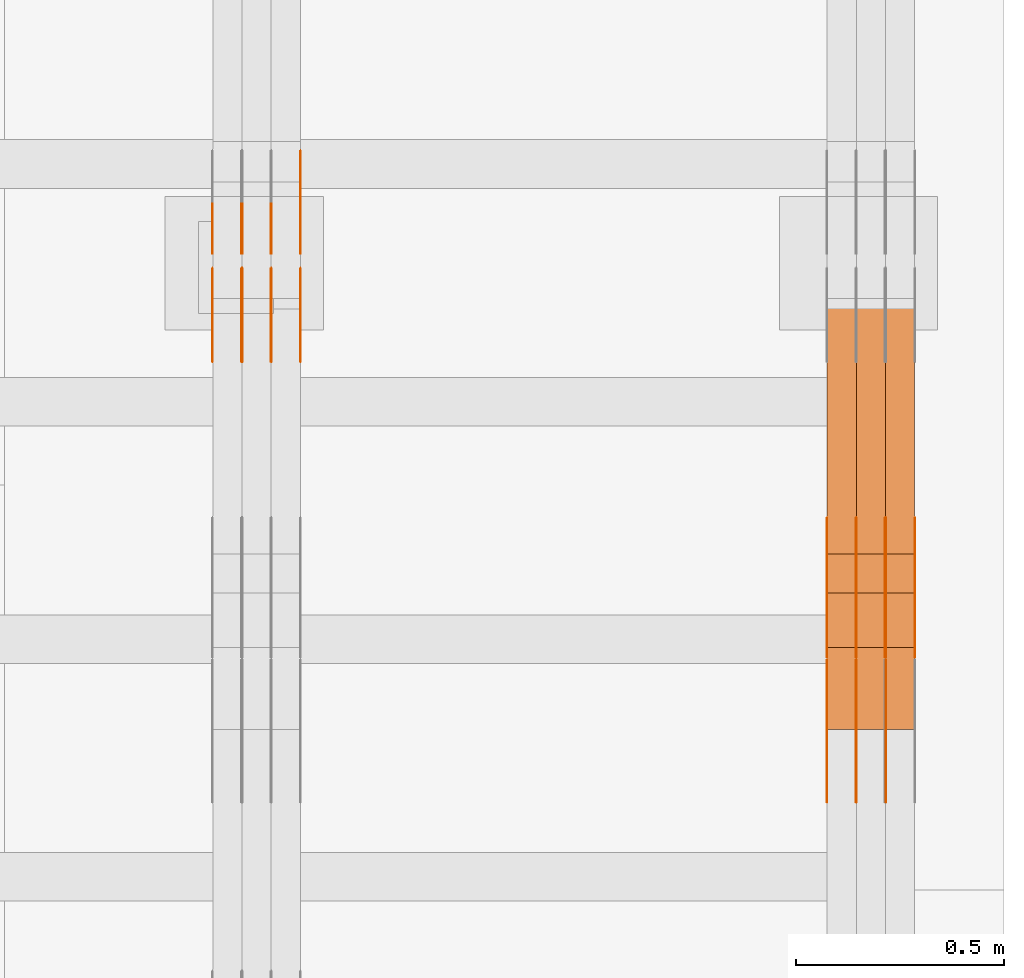
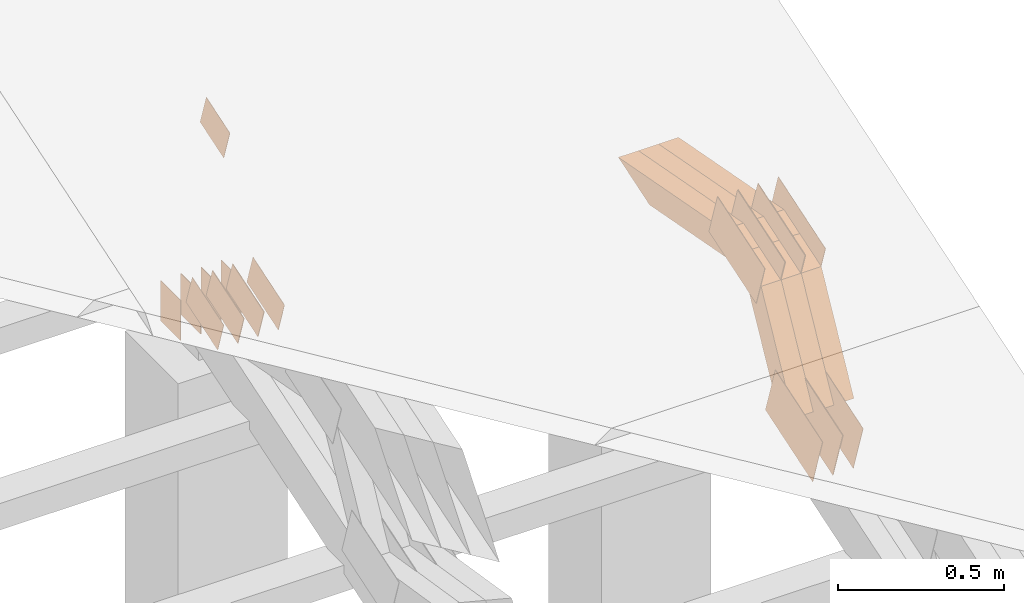
# One storey, part 320 of 385: 29 proxies.
"""IFC2X3 building model written with IfcOpenShell, lengths in millimetres."""

from ifc_helpers import new_model, entity, si_unit, converted_unit, derived_unit, direction, frame, frame_2d, origin, place, context, subcontext, project, spatial, polyline, rectangle, outline, extrude, source, transform, mapped, material, type_object, type_shapes, element, save


model = new_model("IFC2X3")

# Units and contexts
model_context = context("Model", 3, precision=0.01, world=origin(), true_north=direction((6.12303176911189e-17, 1.0)))
body_context = subcontext(model_context, "Body", "Model", "MODEL_VIEW")
ifc_project = project(units=[si_unit("LENGTHUNIT", "METRE", prefix="MILLI"), si_unit("AREAUNIT", "SQUARE_METRE"), si_unit("VOLUMEUNIT", "CUBIC_METRE"), converted_unit("PLANEANGLEUNIT", "DEGREE", entity("IfcRatioMeasure", 0.0174532925199433), si_unit("PLANEANGLEUNIT", "RADIAN"), dimensions=[0, 0, 0, 0, 0, 0, 0]), si_unit("MASSUNIT", "GRAM", prefix="KILO"), derived_unit("MASSDENSITYUNIT", [(si_unit("MASSUNIT", "GRAM", prefix="KILO"), 1), (si_unit("LENGTHUNIT", "METRE"), -3)]), si_unit("TIMEUNIT", "SECOND"), si_unit("FREQUENCYUNIT", "HERTZ"), si_unit("THERMODYNAMICTEMPERATUREUNIT", "DEGREE_CELSIUS"), derived_unit("THERMALTRANSMITTANCEUNIT", [(si_unit("MASSUNIT", "GRAM", prefix="KILO"), 1), (si_unit("THERMODYNAMICTEMPERATUREUNIT", "KELVIN"), -1), (si_unit("TIMEUNIT", "SECOND"), -3)]), derived_unit("VOLUMETRICFLOWRATEUNIT", [(si_unit("LENGTHUNIT", "METRE"), 3), (si_unit("TIMEUNIT", "SECOND"), -1)]), si_unit("ELECTRICCURRENTUNIT", "AMPERE"), si_unit("ELECTRICVOLTAGEUNIT", "VOLT"), si_unit("POWERUNIT", "WATT"), si_unit("FORCEUNIT", "NEWTON", prefix="KILO"), si_unit("ILLUMINANCEUNIT", "LUX"), si_unit("LUMINOUSFLUXUNIT", "LUMEN"), si_unit("LUMINOUSINTENSITYUNIT", "CANDELA"), derived_unit("USERDEFINED", [(si_unit("MASSUNIT", "GRAM", prefix="KILO"), -1), (si_unit("LENGTHUNIT", "METRE"), -2), (si_unit("TIMEUNIT", "SECOND"), 3), (si_unit("LUMINOUSFLUXUNIT", "LUMEN"), 1)]), derived_unit("LINEARVELOCITYUNIT", [(si_unit("LENGTHUNIT", "METRE"), 1), (si_unit("TIMEUNIT", "SECOND"), -1)]), si_unit("PRESSUREUNIT", "PASCAL"), derived_unit("USERDEFINED", [(si_unit("LENGTHUNIT", "METRE"), -2), (si_unit("MASSUNIT", "GRAM", prefix="KILO"), 1), (si_unit("TIMEUNIT", "SECOND"), -2)])], contexts=[model_context])

# Site, building, storey
site_placement = place(None, origin())
site = spatial("IfcSite", under=ifc_project, at=site_placement, CompositionType="ELEMENT")
building_placement = place(site_placement, origin())
building = spatial("IfcBuilding", under=site, at=building_placement, CompositionType="ELEMENT")
storey_placement = place(building_placement, origin())
storey = spatial("IfcBuildingStorey", under=building, at=storey_placement, Name="Default", CompositionType="ELEMENT", Elevation=0.0)

# Proxies
ifc_material_1 = material(Name="IfcSurfaceStyle #621526")
building_element_proxy_type_1 = type_object("IfcBuildingElementProxyType", PredefinedType="NOTDEFINED", material=ifc_material_1)
shared_shape_1 = source(origin(), body_context, "Body", "SweptSolid", [
    extrude(outline(polyline([(-149.99966632326, -95.9999759039407), (149.999881095801, -95.9999759039407), (150.000557367591, 95.9999759039407), (-150.000772140132, 95.9999759039406), (-149.99966632326, -95.9999759039407)])), frame((150.000557367591, 96.0004291135906, 0.0), z_axis=(0.0, 0.0, 1.0), x_axis=(-1.0, 0.0, 0.0)), (0.0, 0.0, 1.0), 1.29999999999999),
])
type_shapes(building_element_proxy_type_1, [shared_shape_1])
proxy_1_placement = place(building_placement, frame((49791.3, 10934.7734375, 2766.8759765625), z_axis=(-1.0, 0.0, 0.0), x_axis=(0.0, 0.951056516295124, 0.309016994375039)))
element("IfcBuildingElementProxy", 1, at=proxy_1_placement, inside=storey, type_object=building_element_proxy_type_1, material=ifc_material_1, context=body_context, shape_type="MappedRepresentation", body=[
    mapped(shared_shape_1, transform((0.0, 0.0, 0.0), scale=1.0)),
])
ifc_material_2 = material(Name="IfcSurfaceStyle #621469")
building_element_proxy_type_2 = type_object("IfcBuildingElementProxyType", PredefinedType="NOTDEFINED", material=ifc_material_2)
shared_shape_2 = source(origin(), body_context, "Body", "SweptSolid", [
    extrude(outline(polyline([(-149.99966632326, -95.9999759039407), (149.999881095801, -95.9999759039407), (150.000557367591, 95.9999759039407), (-150.000772140132, 95.9999759039406), (-149.99966632326, -95.9999759039407)])), frame((150.000557367591, 96.0004291135906, 0.0), z_axis=(0.0, 0.0, 1.0), x_axis=(-1.0, 0.0, 0.0)), (0.0, 0.0, 1.0), 1.29999999999998),
])
type_shapes(building_element_proxy_type_2, [shared_shape_2])
proxy_2_placement = place(building_placement, frame((49720.0, 10934.7734375, 2766.8759765625), z_axis=(-1.0, 0.0, 0.0), x_axis=(0.0, 0.951056516295124, 0.309016994375039)))
element("IfcBuildingElementProxy", 2, at=proxy_2_placement, inside=storey, type_object=building_element_proxy_type_2, material=ifc_material_2, context=body_context, shape_type="MappedRepresentation", body=[
    mapped(shared_shape_2, transform((0.0, 0.0, 0.0), scale=1.0)),
])
ifc_material_3 = material(Name="IfcSurfaceStyle #621412")
building_element_proxy_type_3 = type_object("IfcBuildingElementProxyType", PredefinedType="NOTDEFINED", material=ifc_material_3)
shared_shape_3 = source(origin(), body_context, "Body", "SweptSolid", [
    extrude(outline(polyline([(-149.99966632326, -95.9999759039407), (149.999881095801, -95.9999759039407), (150.000557367591, 95.9999759039407), (-150.000772140132, 95.9999759039406), (-149.99966632326, -95.9999759039407)])), frame((150.000557367591, 96.0004291135906, 0.0), z_axis=(0.0, 0.0, 1.0), x_axis=(-1.0, 0.0, 0.0)), (0.0, 0.0, 1.0), 1.29999999999998),
])
type_shapes(building_element_proxy_type_3, [shared_shape_3])
proxy_3_placement = place(building_placement, frame((49721.3, 10934.7734375, 2766.8759765625), z_axis=(-1.0, 0.0, 0.0), x_axis=(0.0, 0.951056516295124, 0.309016994375039)))
element("IfcBuildingElementProxy", 3, at=proxy_3_placement, inside=storey, type_object=building_element_proxy_type_3, material=ifc_material_3, context=body_context, shape_type="MappedRepresentation", body=[
    mapped(shared_shape_3, transform((0.0, 0.0, 0.0), scale=1.0)),
])
ifc_material_4 = material(Name="IfcSurfaceStyle #621355")
building_element_proxy_type_4 = type_object("IfcBuildingElementProxyType", PredefinedType="NOTDEFINED", material=ifc_material_4)
shared_shape_4 = source(origin(), body_context, "Body", "SweptSolid", [
    extrude(outline(polyline([(-149.99966632326, -95.9999759039407), (149.999881095801, -95.9999759039407), (150.000557367591, 95.9999759039407), (-150.000772140132, 95.9999759039406), (-149.99966632326, -95.9999759039407)])), frame((150.000557367591, 96.0004291135906, 0.0), z_axis=(0.0, 0.0, 1.0), x_axis=(-1.0, 0.0, 0.0)), (0.0, 0.0, 1.0), 1.29999999999998),
])
type_shapes(building_element_proxy_type_4, [shared_shape_4])
proxy_4_placement = place(building_placement, frame((49650.0, 10934.7734375, 2766.8759765625), z_axis=(-1.0, 0.0, 0.0), x_axis=(0.0, 0.951056516295124, 0.309016994375039)))
element("IfcBuildingElementProxy", 4, at=proxy_4_placement, inside=storey, type_object=building_element_proxy_type_4, material=ifc_material_4, context=body_context, shape_type="MappedRepresentation", body=[
    mapped(shared_shape_4, transform((0.0, 0.0, 0.0), scale=1.0)),
])
ifc_material_5 = material(Name="IfcSurfaceStyle #612064")
building_element_proxy_type_5 = type_object("IfcBuildingElementProxyType", PredefinedType="NOTDEFINED", material=ifc_material_5)
shared_shape_5 = source(origin(), body_context, "Body", "SweptSolid", [
    extrude(outline(polyline([(-150.000273478628, -84.0002987844282), (149.999198496832, -84.0002987844282), (150.000273478627, 84.0002987844282), (-149.999198496831, 84.0002987844282), (-150.000273478628, -84.0002987844282)])), frame((150.000273478627, 84.0002987844282, 0.0), z_axis=(0.0, 0.0, 1.0), x_axis=(-1.0, 0.0, 0.0)), (0.0, 0.0, 1.0), 1.29999999999999),
])
type_shapes(building_element_proxy_type_5, [shared_shape_5])
proxy_5_placement = place(building_placement, frame((49861.3, 11283.0116722926, 3194.09682266857), z_axis=(-1.0, 0.0, 0.0), x_axis=(0.0, 0.951056516295154, 0.309016994374948)))
element("IfcBuildingElementProxy", 5, at=proxy_5_placement, inside=storey, type_object=building_element_proxy_type_5, material=ifc_material_5, context=body_context, shape_type="MappedRepresentation", body=[
    mapped(shared_shape_5, transform((0.0, 0.0, 0.0), scale=1.0)),
])
ifc_material_6 = material(Name="IfcSurfaceStyle #612007")
building_element_proxy_type_6 = type_object("IfcBuildingElementProxyType", PredefinedType="NOTDEFINED", material=ifc_material_6)
shared_shape_6 = source(origin(), body_context, "Body", "SweptSolid", [
    extrude(outline(polyline([(-150.000273478628, -84.0002987844282), (149.999198496832, -84.0002987844282), (150.000273478627, 84.0002987844282), (-149.999198496831, 84.0002987844282), (-150.000273478628, -84.0002987844282)])), frame((150.000273478627, 84.0002987844282, 0.0), z_axis=(0.0, 0.0, 1.0), x_axis=(-1.0, 0.0, 0.0)), (0.0, 0.0, 1.0), 1.29999999999999),
])
type_shapes(building_element_proxy_type_6, [shared_shape_6])
proxy_6_placement = place(building_placement, frame((49790.0, 11283.0116722926, 3194.09682266857), z_axis=(-1.0, 0.0, 0.0), x_axis=(0.0, 0.951056516295154, 0.309016994374948)))
element("IfcBuildingElementProxy", 6, at=proxy_6_placement, inside=storey, type_object=building_element_proxy_type_6, material=ifc_material_6, context=body_context, shape_type="MappedRepresentation", body=[
    mapped(shared_shape_6, transform((0.0, 0.0, 0.0), scale=1.0)),
])
ifc_material_7 = material(Name="IfcSurfaceStyle #611950")
building_element_proxy_type_7 = type_object("IfcBuildingElementProxyType", PredefinedType="NOTDEFINED", material=ifc_material_7)
shared_shape_7 = source(origin(), body_context, "Body", "SweptSolid", [
    extrude(outline(polyline([(-150.000273478628, -84.0002987844282), (149.999198496832, -84.0002987844282), (150.000273478627, 84.0002987844282), (-149.999198496831, 84.0002987844282), (-150.000273478628, -84.0002987844282)])), frame((150.000273478627, 84.0002987844282, 0.0), z_axis=(0.0, 0.0, 1.0), x_axis=(-1.0, 0.0, 0.0)), (0.0, 0.0, 1.0), 1.29999999999999),
])
type_shapes(building_element_proxy_type_7, [shared_shape_7])
proxy_7_placement = place(building_placement, frame((49791.3, 11283.0116722926, 3194.09682266857), z_axis=(-1.0, 0.0, 0.0), x_axis=(0.0, 0.951056516295154, 0.309016994374948)))
element("IfcBuildingElementProxy", 7, at=proxy_7_placement, inside=storey, type_object=building_element_proxy_type_7, material=ifc_material_7, context=body_context, shape_type="MappedRepresentation", body=[
    mapped(shared_shape_7, transform((0.0, 0.0, 0.0), scale=1.0)),
])
ifc_material_8 = material(Name="IfcSurfaceStyle #611893")
building_element_proxy_type_8 = type_object("IfcBuildingElementProxyType", PredefinedType="NOTDEFINED", material=ifc_material_8)
shared_shape_8 = source(origin(), body_context, "Body", "SweptSolid", [
    extrude(outline(polyline([(-150.000273478628, -84.0002987844282), (149.999198496832, -84.0002987844282), (150.000273478627, 84.0002987844282), (-149.999198496831, 84.0002987844282), (-150.000273478628, -84.0002987844282)])), frame((150.000273478627, 84.0002987844282, 0.0), z_axis=(0.0, 0.0, 1.0), x_axis=(-1.0, 0.0, 0.0)), (0.0, 0.0, 1.0), 1.29999999999998),
])
type_shapes(building_element_proxy_type_8, [shared_shape_8])
proxy_8_placement = place(building_placement, frame((49720.0, 11283.0116722926, 3194.09682266857), z_axis=(-1.0, 0.0, 0.0), x_axis=(0.0, 0.951056516295154, 0.309016994374948)))
element("IfcBuildingElementProxy", 8, at=proxy_8_placement, inside=storey, type_object=building_element_proxy_type_8, material=ifc_material_8, context=body_context, shape_type="MappedRepresentation", body=[
    mapped(shared_shape_8, transform((0.0, 0.0, 0.0), scale=1.0)),
])
ifc_material_9 = material(Name="IfcSurfaceStyle #611836")
building_element_proxy_type_9 = type_object("IfcBuildingElementProxyType", PredefinedType="NOTDEFINED", material=ifc_material_9)
shared_shape_9 = source(origin(), body_context, "Body", "SweptSolid", [
    extrude(outline(polyline([(-150.000273478628, -84.0002987844282), (149.999198496832, -84.0002987844282), (150.000273478627, 84.0002987844282), (-149.999198496831, 84.0002987844282), (-150.000273478628, -84.0002987844282)])), frame((150.000273478627, 84.0002987844282, 0.0), z_axis=(0.0, 0.0, 1.0), x_axis=(-1.0, 0.0, 0.0)), (0.0, 0.0, 1.0), 1.29999999999998),
])
type_shapes(building_element_proxy_type_9, [shared_shape_9])
proxy_9_placement = place(building_placement, frame((49721.3, 11283.0116722926, 3194.09682266857), z_axis=(-1.0, 0.0, 0.0), x_axis=(0.0, 0.951056516295154, 0.309016994374948)))
element("IfcBuildingElementProxy", 9, at=proxy_9_placement, inside=storey, type_object=building_element_proxy_type_9, material=ifc_material_9, context=body_context, shape_type="MappedRepresentation", body=[
    mapped(shared_shape_9, transform((0.0, 0.0, 0.0), scale=1.0)),
])
ifc_material_10 = material(Name="IfcSurfaceStyle #611779")
building_element_proxy_type_10 = type_object("IfcBuildingElementProxyType", PredefinedType="NOTDEFINED", material=ifc_material_10)
shared_shape_10 = source(origin(), body_context, "Body", "SweptSolid", [
    extrude(outline(polyline([(-150.000273478628, -84.0002987844282), (149.999198496832, -84.0002987844282), (150.000273478627, 84.0002987844282), (-149.999198496831, 84.0002987844282), (-150.000273478628, -84.0002987844282)])), frame((150.000273478627, 84.0002987844282, 0.0), z_axis=(0.0, 0.0, 1.0), x_axis=(-1.0, 0.0, 0.0)), (0.0, 0.0, 1.0), 1.29999999999998),
])
type_shapes(building_element_proxy_type_10, [shared_shape_10])
proxy_10_placement = place(building_placement, frame((49650.0, 11283.0116722926, 3194.09682266857), z_axis=(-1.0, 0.0, 0.0), x_axis=(0.0, 0.951056516295154, 0.309016994374948)))
element("IfcBuildingElementProxy", 10, at=proxy_10_placement, inside=storey, type_object=building_element_proxy_type_10, material=ifc_material_10, context=body_context, shape_type="MappedRepresentation", body=[
    mapped(shared_shape_10, transform((0.0, 0.0, 0.0), scale=1.0)),
])
ifc_material_11 = material(Name="IfcSurfaceStyle #601768")
building_element_proxy_type_11 = type_object("IfcBuildingElementProxyType", Name="T2-W9 601766", PredefinedType="NOTDEFINED", material=ifc_material_11)
shared_shape_11 = source(origin(), body_context, "Body", "SweptSolid", [
    extrude(outline(polyline([(-287.457507623288, -47.5000268597988), (288.590479960635, -47.5000268597988), (273.55062971372, -2.33146189358546e-05), (186.625054999886, 47.5000385171083), (-461.308657050953, 47.5000385171083), (-287.457507623288, -47.5000268597988)])), frame((288.590945855618, 47.5000968036551, 0.0), z_axis=(0.0, 0.0, 1.0), x_axis=(-1.0, 0.0, 0.0)), (0.0, 0.0, 1.0), 70.0),
])
type_shapes(building_element_proxy_type_11, [shared_shape_11])
proxy_11_placement = place(building_placement, frame((49860.0, 11432.1200855376, 3205.63308612017), z_axis=(-1.0, 0.0, 0.0), x_axis=(0.0, 0.982760503514031, -0.184883186722992)))
element("IfcBuildingElementProxy", 11, at=proxy_11_placement, inside=storey, type_object=building_element_proxy_type_11, material=ifc_material_11, Name="T2-W9", context=body_context, shape_type="MappedRepresentation", body=[
    mapped(shared_shape_11, transform((0.0, 0.0, 0.0), scale=1.0)),
])
ifc_material_12 = material(Name="IfcSurfaceStyle #601702")
building_element_proxy_type_12 = type_object("IfcBuildingElementProxyType", Name="T2-W9 601700", PredefinedType="NOTDEFINED", material=ifc_material_12)
shared_shape_12 = source(origin(), body_context, "Body", "SweptSolid", [
    extrude(outline(polyline([(-287.457507623288, -47.5000268597988), (288.590479960635, -47.5000268597988), (273.55062971372, -2.33146189358546e-05), (186.625054999886, 47.5000385171083), (-461.308657050953, 47.5000385171083), (-287.457507623288, -47.5000268597988)])), frame((288.590945855618, 47.5000968036551, 0.0), z_axis=(0.0, 0.0, 1.0), x_axis=(-1.0, 0.0, 0.0)), (0.0, 0.0, 1.0), 70.0),
])
type_shapes(building_element_proxy_type_12, [shared_shape_12])
proxy_12_placement = place(building_placement, frame((49790.0, 11432.1200855376, 3205.63308612017), z_axis=(-1.0, 0.0, 0.0), x_axis=(0.0, 0.982760503514031, -0.184883186722992)))
element("IfcBuildingElementProxy", 12, at=proxy_12_placement, inside=storey, type_object=building_element_proxy_type_12, material=ifc_material_12, Name="T2-W9", context=body_context, shape_type="MappedRepresentation", body=[
    mapped(shared_shape_12, transform((0.0, 0.0, 0.0), scale=1.0)),
])
ifc_material_13 = material(Name="IfcSurfaceStyle #601636")
building_element_proxy_type_13 = type_object("IfcBuildingElementProxyType", Name="T2-W9 601634", PredefinedType="NOTDEFINED", material=ifc_material_13)
shared_shape_13 = source(origin(), body_context, "Body", "SweptSolid", [
    extrude(outline(polyline([(-287.457507623288, -47.5000268597988), (288.590479960635, -47.5000268597988), (273.55062971372, -2.33146189358546e-05), (186.625054999886, 47.5000385171083), (-461.308657050953, 47.5000385171083), (-287.457507623288, -47.5000268597988)])), frame((288.590945855618, 47.5000968036551, 0.0), z_axis=(0.0, 0.0, 1.0), x_axis=(-1.0, 0.0, 0.0)), (0.0, 0.0, 1.0), 70.0),
])
type_shapes(building_element_proxy_type_13, [shared_shape_13])
proxy_13_placement = place(building_placement, frame((49720.0, 11432.1200855376, 3205.63308612017), z_axis=(-1.0, 0.0, 0.0), x_axis=(0.0, 0.982760503514031, -0.184883186722992)))
element("IfcBuildingElementProxy", 13, at=proxy_13_placement, inside=storey, type_object=building_element_proxy_type_13, material=ifc_material_13, Name="T2-W9", context=body_context, shape_type="MappedRepresentation", body=[
    mapped(shared_shape_13, transform((0.0, 0.0, 0.0), scale=1.0)),
])
ifc_material_14 = material(Name="IfcSurfaceStyle #601372")
building_element_proxy_type_14 = type_object("IfcBuildingElementProxyType", Name="T2-W32 601370", PredefinedType="NOTDEFINED", material=ifc_material_14)
shared_shape_14 = source(origin(), body_context, "Body", "SweptSolid", [
    extrude(outline(polyline([(-312.414547135921, -47.5000544873059), (136.677011757652, -47.5000544873059), (186.250996577889, 0.000369497452627243), (202.753116295831, 47.4998697385796), (-213.26657749545, 47.4998697385796), (-312.414547135921, -47.5000544873059)])), frame((202.753376481939, 47.5001296985553, 0.0), z_axis=(0.0, 0.0, 1.0), x_axis=(-1.0, 0.0, 0.0)), (0.0, 0.0, 1.0), 70.0),
])
type_shapes(building_element_proxy_type_14, [shared_shape_14])
proxy_14_placement = place(building_placement, frame((49860.0, 11110.7808979007, 2747.18129017315), z_axis=(-1.0, 0.0, 0.0), x_axis=(0.0, 0.472919689385906, 0.881105537033526)))
element("IfcBuildingElementProxy", 14, at=proxy_14_placement, inside=storey, type_object=building_element_proxy_type_14, material=ifc_material_14, Name="T2-W32", context=body_context, shape_type="MappedRepresentation", body=[
    mapped(shared_shape_14, transform((0.0, 0.0, 0.0), scale=1.0)),
])
ifc_material_15 = material(Name="IfcSurfaceStyle #601306")
building_element_proxy_type_15 = type_object("IfcBuildingElementProxyType", Name="T2-W32 601304", PredefinedType="NOTDEFINED", material=ifc_material_15)
shared_shape_15 = source(origin(), body_context, "Body", "SweptSolid", [
    extrude(outline(polyline([(-312.414547135921, -47.5000544873059), (136.677011757652, -47.5000544873059), (186.250996577889, 0.000369497452627243), (202.753116295831, 47.4998697385796), (-213.26657749545, 47.4998697385796), (-312.414547135921, -47.5000544873059)])), frame((202.753376481939, 47.5001296985553, 0.0), z_axis=(0.0, 0.0, 1.0), x_axis=(-1.0, 0.0, 0.0)), (0.0, 0.0, 1.0), 70.0),
])
type_shapes(building_element_proxy_type_15, [shared_shape_15])
proxy_15_placement = place(building_placement, frame((49790.0, 11110.7808979007, 2747.18129017315), z_axis=(-1.0, 0.0, 0.0), x_axis=(0.0, 0.472919689385906, 0.881105537033526)))
element("IfcBuildingElementProxy", 15, at=proxy_15_placement, inside=storey, type_object=building_element_proxy_type_15, material=ifc_material_15, Name="T2-W32", context=body_context, shape_type="MappedRepresentation", body=[
    mapped(shared_shape_15, transform((0.0, 0.0, 0.0), scale=1.0)),
])
ifc_material_16 = material(Name="IfcSurfaceStyle #601240")
building_element_proxy_type_16 = type_object("IfcBuildingElementProxyType", Name="T2-W32 601238", PredefinedType="NOTDEFINED", material=ifc_material_16)
shared_shape_16 = source(origin(), body_context, "Body", "SweptSolid", [
    extrude(outline(polyline([(-312.414547135921, -47.5000544873059), (136.677011757652, -47.5000544873059), (186.250996577889, 0.000369497452627243), (202.753116295831, 47.4998697385796), (-213.26657749545, 47.4998697385796), (-312.414547135921, -47.5000544873059)])), frame((202.753376481939, 47.5001296985553, 0.0), z_axis=(0.0, 0.0, 1.0), x_axis=(-1.0, 0.0, 0.0)), (0.0, 0.0, 1.0), 70.0),
])
type_shapes(building_element_proxy_type_16, [shared_shape_16])
proxy_16_placement = place(building_placement, frame((49720.0, 11110.7808979007, 2747.18129017315), z_axis=(-1.0, 0.0, 0.0), x_axis=(0.0, 0.472919689385906, 0.881105537033526)))
element("IfcBuildingElementProxy", 16, at=proxy_16_placement, inside=storey, type_object=building_element_proxy_type_16, material=ifc_material_16, Name="T2-W32", context=body_context, shape_type="MappedRepresentation", body=[
    mapped(shared_shape_16, transform((0.0, 0.0, 0.0), scale=1.0)),
])
ifc_material_17 = material(Name="IfcSurfaceStyle #585840")
building_element_proxy_type_17 = type_object("IfcBuildingElementProxyType", PredefinedType="NOTDEFINED", material=ifc_material_17)
shared_shape_17 = source(origin(), body_context, "Body", "SweptSolid", [
    extrude(outline(polyline([(-99.9997874178038, -60.0000528641967), (99.9998102700997, -60.0000528641967), (99.9998251396068, 60.0000528641967), (-99.9998479919027, 60.0000528641967), (-99.9997874178038, -60.0000528641967)])), frame((99.9999918898597, 60.0000528641967, 0.0), z_axis=(0.0, 0.0, 1.0), x_axis=(-1.0, 0.0, 0.0)), (0.0, 0.0, 1.0), 1.3),
])
type_shapes(building_element_proxy_type_17, [shared_shape_17])
proxy_17_placement = place(building_placement, frame((48386.3, 11991.9568177725, 3072.52282247925), z_axis=(-1.0, 0.0, 0.0), x_axis=(0.0, 0.951056516295124, 0.309016994375039)))
element("IfcBuildingElementProxy", 17, at=proxy_17_placement, inside=storey, type_object=building_element_proxy_type_17, material=ifc_material_17, context=body_context, shape_type="MappedRepresentation", body=[
    mapped(shared_shape_17, transform((0.0, 0.0, 0.0), scale=1.0)),
])
ifc_material_18 = material(Name="IfcSurfaceStyle #585783")
building_element_proxy_type_18 = type_object("IfcBuildingElementProxyType", PredefinedType="NOTDEFINED", material=ifc_material_18)
shared_shape_18 = source(origin(), body_context, "Body", "SweptSolid", [
    extrude(outline(polyline([(-99.9997874178038, -60.0000528641967), (99.9998102700997, -60.0000528641967), (99.9998251396068, 60.0000528641967), (-99.9998479919027, 60.0000528641967), (-99.9997874178038, -60.0000528641967)])), frame((99.9999918898597, 60.0000528641967, 0.0), z_axis=(0.0, 0.0, 1.0), x_axis=(-1.0, 0.0, 0.0)), (0.0, 0.0, 1.0), 1.3),
])
type_shapes(building_element_proxy_type_18, [shared_shape_18])
proxy_18_placement = place(building_placement, frame((48315.0, 11991.9568177725, 3072.52282247925), z_axis=(-1.0, 0.0, 0.0), x_axis=(0.0, 0.951056516295124, 0.309016994375039)))
element("IfcBuildingElementProxy", 18, at=proxy_18_placement, inside=storey, type_object=building_element_proxy_type_18, material=ifc_material_18, context=body_context, shape_type="MappedRepresentation", body=[
    mapped(shared_shape_18, transform((0.0, 0.0, 0.0), scale=1.0)),
])
ifc_material_19 = material(Name="IfcSurfaceStyle #585726")
building_element_proxy_type_19 = type_object("IfcBuildingElementProxyType", PredefinedType="NOTDEFINED", material=ifc_material_19)
shared_shape_19 = source(origin(), body_context, "Body", "SweptSolid", [
    extrude(outline(polyline([(-99.9997874178038, -60.0000528641967), (99.9998102700997, -60.0000528641967), (99.9998251396068, 60.0000528641967), (-99.9998479919027, 60.0000528641967), (-99.9997874178038, -60.0000528641967)])), frame((99.9999918898597, 60.0000528641967, 0.0), z_axis=(0.0, 0.0, 1.0), x_axis=(-1.0, 0.0, 0.0)), (0.0, 0.0, 1.0), 1.3),
])
type_shapes(building_element_proxy_type_19, [shared_shape_19])
proxy_19_placement = place(building_placement, frame((48316.3, 11991.9568177725, 3072.52282247925), z_axis=(-1.0, 0.0, 0.0), x_axis=(0.0, 0.951056516295124, 0.309016994375039)))
element("IfcBuildingElementProxy", 19, at=proxy_19_placement, inside=storey, type_object=building_element_proxy_type_19, material=ifc_material_19, context=body_context, shape_type="MappedRepresentation", body=[
    mapped(shared_shape_19, transform((0.0, 0.0, 0.0), scale=1.0)),
])
ifc_material_20 = material(Name="IfcSurfaceStyle #585669")
building_element_proxy_type_20 = type_object("IfcBuildingElementProxyType", PredefinedType="NOTDEFINED", material=ifc_material_20)
shared_shape_20 = source(origin(), body_context, "Body", "SweptSolid", [
    extrude(outline(polyline([(-99.9997874178038, -60.0000528641967), (99.9998102700997, -60.0000528641967), (99.9998251396068, 60.0000528641967), (-99.9998479919027, 60.0000528641967), (-99.9997874178038, -60.0000528641967)])), frame((99.9999918898597, 60.0000528641967, 0.0), z_axis=(0.0, 0.0, 1.0), x_axis=(-1.0, 0.0, 0.0)), (0.0, 0.0, 1.0), 1.29999999999998),
])
type_shapes(building_element_proxy_type_20, [shared_shape_20])
proxy_20_placement = place(building_placement, frame((48245.0, 11991.9568177725, 3072.52282247925), z_axis=(-1.0, 0.0, 0.0), x_axis=(0.0, 0.951056516295124, 0.309016994375039)))
element("IfcBuildingElementProxy", 20, at=proxy_20_placement, inside=storey, type_object=building_element_proxy_type_20, material=ifc_material_20, context=body_context, shape_type="MappedRepresentation", body=[
    mapped(shared_shape_20, transform((0.0, 0.0, 0.0), scale=1.0)),
])
ifc_material_21 = material(Name="IfcSurfaceStyle #585612")
building_element_proxy_type_21 = type_object("IfcBuildingElementProxyType", PredefinedType="NOTDEFINED", material=ifc_material_21)
shared_shape_21 = source(origin(), body_context, "Body", "SweptSolid", [
    extrude(outline(polyline([(-99.9997874178038, -60.0000528641967), (99.9998102700997, -60.0000528641967), (99.9998251396068, 60.0000528641967), (-99.9998479919027, 60.0000528641967), (-99.9997874178038, -60.0000528641967)])), frame((99.9999918898597, 60.0000528641967, 0.0), z_axis=(0.0, 0.0, 1.0), x_axis=(-1.0, 0.0, 0.0)), (0.0, 0.0, 1.0), 1.29999999999998),
])
type_shapes(building_element_proxy_type_21, [shared_shape_21])
proxy_21_placement = place(building_placement, frame((48246.3, 11991.9568177725, 3072.52282247925), z_axis=(-1.0, 0.0, 0.0), x_axis=(0.0, 0.951056516295124, 0.309016994375039)))
element("IfcBuildingElementProxy", 21, at=proxy_21_placement, inside=storey, type_object=building_element_proxy_type_21, material=ifc_material_21, context=body_context, shape_type="MappedRepresentation", body=[
    mapped(shared_shape_21, transform((0.0, 0.0, 0.0), scale=1.0)),
])
ifc_material_22 = material(Name="IfcSurfaceStyle #585555")
building_element_proxy_type_22 = type_object("IfcBuildingElementProxyType", PredefinedType="NOTDEFINED", material=ifc_material_22)
shared_shape_22 = source(origin(), body_context, "Body", "SweptSolid", [
    extrude(outline(polyline([(-99.9997874178038, -60.0000528641967), (99.9998102700997, -60.0000528641967), (99.9998251396068, 60.0000528641967), (-99.9998479919027, 60.0000528641967), (-99.9997874178038, -60.0000528641967)])), frame((99.9999918898597, 60.0000528641967, 0.0), z_axis=(0.0, 0.0, 1.0), x_axis=(-1.0, 0.0, 0.0)), (0.0, 0.0, 1.0), 1.29999999999999),
])
type_shapes(building_element_proxy_type_22, [shared_shape_22])
proxy_22_placement = place(building_placement, frame((48175.0, 11991.9568177725, 3072.52282247925), z_axis=(-1.0, 0.0, 0.0), x_axis=(0.0, 0.951056516295124, 0.309016994375039)))
element("IfcBuildingElementProxy", 22, at=proxy_22_placement, inside=storey, type_object=building_element_proxy_type_22, material=ifc_material_22, context=body_context, shape_type="MappedRepresentation", body=[
    mapped(shared_shape_22, transform((0.0, 0.0, 0.0), scale=1.0)),
])
ifc_material_23 = material(Name="IfcSurfaceStyle #585498")
building_element_proxy_type_23 = type_object("IfcBuildingElementProxyType", PredefinedType="NOTDEFINED", material=ifc_material_23)
shared_shape_23 = source(origin(), body_context, "Body", "SweptSolid", [
    extrude(rectangle(XDim=150.0, YDim=119.999999999985, at=frame_2d((-7.105427357601e-15, 0.0), x_axis=(1.0, 0.0))), frame((75.0, 60.0, 0.0), z_axis=(0.0, 0.0, 1.0), x_axis=(-1.0, 0.0, 0.0)), (0.0, 0.0, 1.0), 1.3),
])
type_shapes(building_element_proxy_type_23, [shared_shape_23])
proxy_23_placement = place(building_placement, frame((48386.3, 12372.95703125, 3007.04687500001), z_axis=(-1.0, 0.0, 0.0), x_axis=(0.0, 0.0, -1.0)))
element("IfcBuildingElementProxy", 23, at=proxy_23_placement, inside=storey, type_object=building_element_proxy_type_23, material=ifc_material_23, context=body_context, shape_type="MappedRepresentation", body=[
    mapped(shared_shape_23, transform((0.0, 0.0, 0.0), scale=1.0)),
])
ifc_material_24 = material(Name="IfcSurfaceStyle #585441")
building_element_proxy_type_24 = type_object("IfcBuildingElementProxyType", PredefinedType="NOTDEFINED", material=ifc_material_24)
shared_shape_24 = source(origin(), body_context, "Body", "SweptSolid", [
    extrude(rectangle(XDim=150.0, YDim=119.999999999985, at=frame_2d((-7.105427357601e-15, 0.0), x_axis=(1.0, 0.0))), frame((75.0, 60.0, 0.0), z_axis=(0.0, 0.0, 1.0), x_axis=(-1.0, 0.0, 0.0)), (0.0, 0.0, 1.0), 1.3),
])
type_shapes(building_element_proxy_type_24, [shared_shape_24])
proxy_24_placement = place(building_placement, frame((48315.0, 12372.95703125, 3007.04687500001), z_axis=(-1.0, 0.0, 0.0), x_axis=(0.0, 0.0, -1.0)))
element("IfcBuildingElementProxy", 24, at=proxy_24_placement, inside=storey, type_object=building_element_proxy_type_24, material=ifc_material_24, context=body_context, shape_type="MappedRepresentation", body=[
    mapped(shared_shape_24, transform((0.0, 0.0, 0.0), scale=1.0)),
])
ifc_material_25 = material(Name="IfcSurfaceStyle #585384")
building_element_proxy_type_25 = type_object("IfcBuildingElementProxyType", PredefinedType="NOTDEFINED", material=ifc_material_25)
shared_shape_25 = source(origin(), body_context, "Body", "SweptSolid", [
    extrude(rectangle(XDim=150.0, YDim=119.999999999985, at=frame_2d((-7.105427357601e-15, 0.0), x_axis=(1.0, 0.0))), frame((75.0, 60.0, 0.0), z_axis=(0.0, 0.0, 1.0), x_axis=(-1.0, 0.0, 0.0)), (0.0, 0.0, 1.0), 1.3),
])
type_shapes(building_element_proxy_type_25, [shared_shape_25])
proxy_25_placement = place(building_placement, frame((48316.3, 12372.95703125, 3007.04687500001), z_axis=(-1.0, 0.0, 0.0), x_axis=(0.0, 0.0, -1.0)))
element("IfcBuildingElementProxy", 25, at=proxy_25_placement, inside=storey, type_object=building_element_proxy_type_25, material=ifc_material_25, context=body_context, shape_type="MappedRepresentation", body=[
    mapped(shared_shape_25, transform((0.0, 0.0, 0.0), scale=1.0)),
])
ifc_material_26 = material(Name="IfcSurfaceStyle #585327")
building_element_proxy_type_26 = type_object("IfcBuildingElementProxyType", PredefinedType="NOTDEFINED", material=ifc_material_26)
shared_shape_26 = source(origin(), body_context, "Body", "SweptSolid", [
    extrude(rectangle(XDim=150.0, YDim=119.999999999985, at=frame_2d((-7.105427357601e-15, 0.0), x_axis=(1.0, 0.0))), frame((75.0, 60.0, 0.0), z_axis=(0.0, 0.0, 1.0), x_axis=(-1.0, 0.0, 0.0)), (0.0, 0.0, 1.0), 1.29999999999999),
])
type_shapes(building_element_proxy_type_26, [shared_shape_26])
proxy_26_placement = place(building_placement, frame((48245.0, 12372.95703125, 3007.04687500001), z_axis=(-1.0, 0.0, 0.0), x_axis=(0.0, 0.0, -1.0)))
element("IfcBuildingElementProxy", 26, at=proxy_26_placement, inside=storey, type_object=building_element_proxy_type_26, material=ifc_material_26, context=body_context, shape_type="MappedRepresentation", body=[
    mapped(shared_shape_26, transform((0.0, 0.0, 0.0), scale=1.0)),
])
ifc_material_27 = material(Name="IfcSurfaceStyle #585270")
building_element_proxy_type_27 = type_object("IfcBuildingElementProxyType", PredefinedType="NOTDEFINED", material=ifc_material_27)
shared_shape_27 = source(origin(), body_context, "Body", "SweptSolid", [
    extrude(rectangle(XDim=150.0, YDim=119.999999999985, at=frame_2d((-7.105427357601e-15, 0.0), x_axis=(1.0, 0.0))), frame((75.0, 60.0, 0.0), z_axis=(0.0, 0.0, 1.0), x_axis=(-1.0, 0.0, 0.0)), (0.0, 0.0, 1.0), 1.29999999999999),
])
type_shapes(building_element_proxy_type_27, [shared_shape_27])
proxy_27_placement = place(building_placement, frame((48246.3, 12372.95703125, 3007.04687500001), z_axis=(-1.0, 0.0, 0.0), x_axis=(0.0, 0.0, -1.0)))
element("IfcBuildingElementProxy", 27, at=proxy_27_placement, inside=storey, type_object=building_element_proxy_type_27, material=ifc_material_27, context=body_context, shape_type="MappedRepresentation", body=[
    mapped(shared_shape_27, transform((0.0, 0.0, 0.0), scale=1.0)),
])
ifc_material_28 = material(Name="IfcSurfaceStyle #585213")
building_element_proxy_type_28 = type_object("IfcBuildingElementProxyType", PredefinedType="NOTDEFINED", material=ifc_material_28)
shared_shape_28 = source(origin(), body_context, "Body", "SweptSolid", [
    extrude(rectangle(XDim=150.0, YDim=119.999999999985, at=frame_2d((-7.105427357601e-15, 0.0), x_axis=(1.0, 0.0))), frame((75.0, 60.0, 0.0), z_axis=(0.0, 0.0, 1.0), x_axis=(-1.0, 0.0, 0.0)), (0.0, 0.0, 1.0), 1.29999999999999),
])
type_shapes(building_element_proxy_type_28, [shared_shape_28])
proxy_28_placement = place(building_placement, frame((48175.0, 12372.95703125, 3007.04687500001), z_axis=(-1.0, 0.0, 0.0), x_axis=(0.0, 0.0, -1.0)))
element("IfcBuildingElementProxy", 28, at=proxy_28_placement, inside=storey, type_object=building_element_proxy_type_28, material=ifc_material_28, context=body_context, shape_type="MappedRepresentation", body=[
    mapped(shared_shape_28, transform((0.0, 0.0, 0.0), scale=1.0)),
])
ifc_material_29 = material(Name="IfcSurfaceStyle #578316")
building_element_proxy_type_29 = type_object("IfcBuildingElementProxyType", PredefinedType="NOTDEFINED", material=ifc_material_29)
shared_shape_29 = source(origin(), body_context, "Body", "SweptSolid", [
    extrude(outline(polyline([(-74.9998754286244, -60.0000016373506), (74.9998605591063, -60.0000016373506), (74.9998754286244, 60.0000016373506), (-74.9998605591063, 60.0000016373506), (-74.9998754286244, -60.0000016373506)])), frame((74.9998754286244, 60.0000016373506, 0.0), z_axis=(0.0, 0.0, 1.0), x_axis=(-1.0, 0.0, 0.0)), (0.0, 0.0, 1.0), 1.3),
])
type_shapes(building_element_proxy_type_29, [shared_shape_29])
proxy_29_placement = place(building_placement, frame((48386.3, 12321.1620861463, 3506.17707344366), z_axis=(-1.0, 0.0, 0.0), x_axis=(0.0, 0.951056516295154, 0.309016994374948)))
element("IfcBuildingElementProxy", 29, at=proxy_29_placement, inside=storey, type_object=building_element_proxy_type_29, material=ifc_material_29, context=body_context, shape_type="MappedRepresentation", body=[
    mapped(shared_shape_29, transform((0.0, 0.0, 0.0), scale=1.0)),
])

save(model, "model.ifc")
